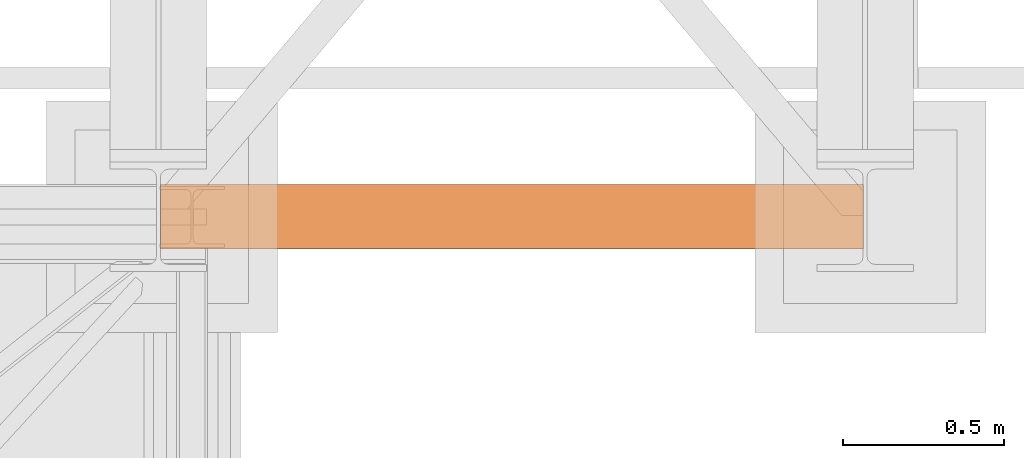
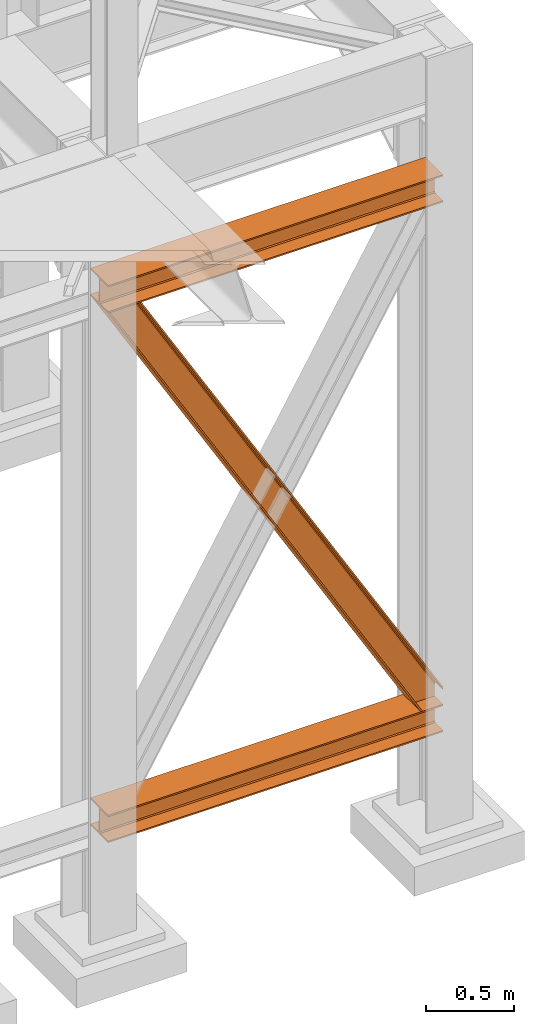
# One storey, part 80 of 208: 3 proxies.
"""IFC2X3 building model written with IfcOpenShell, lengths in millimetres."""

import ifcopenshell
import ifcopenshell.guid

model = None  # the IFC model being written
_history = None  # IfcOwnerHistory: only IFC2X3 demands one
_inside = {}  # id of a spatial element -> (the spatial element, [elements in it])
_under = {}  # id of a project, library or spatial element -> (it, [spatial elements below it])
_declared = {}  # id of a project -> (the project, [libraries it declares])
_typed = {}  # id of a type object -> (the type object, [elements of that type])
_made_of = {}  # id of a material, layer set ... -> (it, [elements and type objects made of it])


def new_model(schema):
    """Start an empty IFC model of exactly this schema.

    Asked for "IFC4X3", IfcOpenShell would pick the latest addendum, in which some entities
    have other attributes; the version numbers below select the first issue.
    IFC2X3 requires an IfcOwnerHistory on every rooted entity: one is made here for all.
    """
    global model, _history
    if schema == "IFC4X3":
        model = ifcopenshell.file(schema_version=(4, 3, 0, 0))
    else:
        model = ifcopenshell.file(schema=schema)
    _inside.clear()
    _under.clear()
    _declared.clear()
    _typed.clear()
    _made_of.clear()
    _history = None
    if model.schema == "IFC2X3":
        org = make("IfcOrganization", Name="unknown")
        user = make(
            "IfcPersonAndOrganization",
            ThePerson=make("IfcPerson", FamilyName="unknown"),
            TheOrganization=org,
        )
        app = make(
            "IfcApplication",
            ApplicationDeveloper=org,
            Version="unknown",
            ApplicationFullName="unknown",
            ApplicationIdentifier="unknown",
        )
        _history = make(
            "IfcOwnerHistory",
            OwningUser=user,
            OwningApplication=app,
            ChangeAction="ADDED",
            CreationDate=0,
        )
    return model


def make(cls, **values):
    """One entity of the class cls with the attributes given. An attribute that is None is left unset."""
    return model.create_entity(
        cls, **{name: value for name, value in values.items() if value is not None}
    )


def entity(cls, *values):
    """Any entity or typed value of the class cls, its attributes in the order of the schema. None: left unset."""
    e = model.create_entity(cls)
    for i, value in enumerate(values):
        if value is not None:
            e[i] = value
    return e


def rooted(cls, **values):
    """An entity with a GlobalId (a new one), such as an element, a storey or a relation."""
    return make(cls, GlobalId=ifcopenshell.guid.new(), OwnerHistory=_history, **values)


def si_unit(unit_type, name, prefix=None):
    """IfcSIUnit, for example si_unit("LENGTHUNIT", "METRE", prefix="MILLI")."""
    return make("IfcSIUnit", UnitType=unit_type, Prefix=prefix, Name=name)


def converted_unit(unit_type, name, factor, base, dimensions=None, offset=None):
    """IfcConversionBasedUnit, such as the inch: factor (a typed value) times the base unit."""
    return make(
        "IfcConversionBasedUnit"
        if offset is None
        else "IfcConversionBasedUnitWithOffset",
        ConversionOffset=offset,
        Dimensions=None
        if dimensions is None
        else entity("IfcDimensionalExponents", *dimensions),
        UnitType=unit_type,
        Name=name,
        ConversionFactor=make(
            "IfcMeasureWithUnit", ValueComponent=factor, UnitComponent=base
        ),
    )


def assignment(units):
    """IfcUnitAssignment: the units of a project."""
    return None if units is None else make("IfcUnitAssignment", Units=units)


def point(xyz):
    """IfcCartesianPoint."""
    return None if xyz is None else make("IfcCartesianPoint", Coordinates=xyz)


def direction(xyz):
    """IfcDirection."""
    return None if xyz is None else make("IfcDirection", DirectionRatios=xyz)


def frame(location, z_axis=None, x_axis=None):
    """IfcAxis2Placement3D, a coordinate frame: its origin and axes. An axis left out is left unset."""
    return make(
        "IfcAxis2Placement3D",
        Location=point(location),
        Axis=direction(z_axis),
        RefDirection=direction(x_axis),
    )


def origin():
    """The frame at (0, 0, 0) with its axes left unset."""
    return frame((0.0, 0.0, 0.0))


def origin_with_axes():
    """The frame at (0, 0, 0) with the z axis (0, 0, 1) and the x axis (1, 0, 0) written out."""
    return frame((0.0, 0.0, 0.0), z_axis=(0.0, 0.0, 1.0), x_axis=(1.0, 0.0, 0.0))


def place(relative_to, where):
    """IfcLocalPlacement: puts the frame where relative to a parent placement (None: the world)."""
    return make(
        "IfcLocalPlacement", PlacementRelTo=relative_to, RelativePlacement=where
    )


def context(
    kind, dimensions, precision=None, world=None, true_north=None, identifier=None
):
    """IfcGeometricRepresentationContext, for example the 3D "Model" context."""
    return make(
        "IfcGeometricRepresentationContext",
        ContextIdentifier=identifier,
        ContextType=kind,
        CoordinateSpaceDimension=dimensions,
        Precision=precision,
        WorldCoordinateSystem=world,
        TrueNorth=true_north,
    )


def subcontext(parent, identifier, kind, view, scale=None):
    """IfcGeometricRepresentationSubContext, for example "Body" below "Model"."""
    return make(
        "IfcGeometricRepresentationSubContext",
        ContextIdentifier=identifier,
        ContextType=kind,
        ParentContext=parent,
        TargetScale=scale,
        TargetView=view,
    )


def project(units=None, contexts=None):
    """IfcProject with its units and contexts."""
    return rooted(
        "IfcProject",
        Name="project",
        RepresentationContexts=contexts,
        UnitsInContext=assignment(units),
    )


def spatial(cls, under=None, at=None, **own):
    """A site, building, storey or space (cls), placed at a placement, below another one or the project."""
    s = rooted(cls, ObjectPlacement=at, **own)
    if under is not None:
        _under.setdefault(under.id(), (under, []))[1].append(s)
    return s


def faces_of(points, faces, orient=None, outer=None):
    """IfcFace entities. A face is a list of loops; a loop is a list of indices into points, from 0.

    orient and outer hold one flag for each loop. By default every Orientation is true, the
    first loop of a face is its IfcFaceOuterBound and the others are IfcFaceBound.
    """
    made = []
    for i, loops in enumerate(faces):
        bounds = []
        for j, loop in enumerate(loops):
            is_outer = j == 0 if outer is None else outer[i][j]
            bounds.append(
                make(
                    "IfcFaceOuterBound" if is_outer else "IfcFaceBound",
                    Bound=make("IfcPolyLoop", Polygon=[points[k] for k in loop]),
                    Orientation=True if orient is None else orient[i][j],
                )
            )
        made.append(make("IfcFace", Bounds=bounds))
    return made


def faceted_brep(points, faces, orient=None, outer=None, voids=None):
    """IfcFacetedBrep: a solid bounded by flat faces; with voids (closed shells), ...WithVoids."""
    shared = [point(p) for p in points]
    hull = make("IfcClosedShell", CfsFaces=faces_of(shared, faces, orient, outer))
    if voids is None:
        return make("IfcFacetedBrep", Outer=hull)
    return make(
        "IfcFacetedBrepWithVoids",
        Outer=hull,
        Voids=[
            make(cls, CfsFaces=faces_of(shared, fs, o, b)) for cls, fs, o, b in voids
        ],
    )


def shape(context_of_items, identifier, shape_type, items):
    """IfcShapeRepresentation: the items that make up one representation, for example the "Body"."""
    return make(
        "IfcShapeRepresentation",
        ContextOfItems=context_of_items,
        RepresentationIdentifier=identifier,
        RepresentationType=shape_type,
        Items=items,
    )


def made_of(thing, what):
    """Note that an element or type object is made of a material, layer set ...; save() writes the relation."""
    if what is not None:
        _made_of.setdefault(what.id(), (what, []))[1].append(thing)
    return thing


def element(
    cls,
    number,
    at=None,
    inside=None,
    cuts=None,
    type_object=None,
    material=None,
    context=None,
    identifier="Body",
    shape_type=None,
    held_by="IfcProductDefinitionShape",
    body=None,
    shapes=None,
    **own,
):
    """One element of the class cls, such as IfcWall. Its Tag is "e" and its number.

    at: its placement. inside: the storey or other place that contains it. cuts: it is an
    opening in that element (IfcRelVoidsElement). A single representation is given by context,
    identifier, shape_type and body (its items); several are given by shapes. held_by: the class
    of the entity that holds the representations. save() writes the other relations.
    """
    e = rooted(cls, Tag="e%d" % number, ObjectPlacement=at, **own)
    if body is not None:
        shapes = [shape(context, identifier, shape_type, body)]
    if shapes is not None:
        e.Representation = make(held_by, Representations=shapes)
    if inside is not None:
        _inside.setdefault(inside.id(), (inside, []))[1].append(e)
    if cuts is not None:
        rooted(
            "IfcRelVoidsElement", RelatingBuildingElement=cuts, RelatedOpeningElement=e
        )
    if type_object is not None:
        _typed.setdefault(type_object.id(), (type_object, []))[1].append(e)
    return made_of(e, material)


def aggregate(whole, parts):
    """IfcRelAggregates: a whole, such as a stair, and the parts it consists of."""
    return rooted("IfcRelAggregates", RelatingObject=whole, RelatedObjects=parts)


def save(model, path):
    """Write the relations noted so far, then the file.

    IfcRelAggregates (storeys below a building ...), IfcRelContainedInSpatialStructure (elements
    in a storey), IfcRelDefinesByType, IfcRelAssociatesMaterial and IfcRelDeclares: one each for
    every whole, place, type object, material and project.
    """
    for whole, parts in _under.values():
        aggregate(whole, parts)
    for where, things in _inside.values():
        rooted(
            "IfcRelContainedInSpatialStructure",
            RelatedElements=things,
            RelatingStructure=where,
        )
    for kind, things in _typed.values():
        rooted("IfcRelDefinesByType", RelatedObjects=things, RelatingType=kind)
    for what, things in _made_of.values():
        rooted("IfcRelAssociatesMaterial", RelatedObjects=things, RelatingMaterial=what)
    for by, libraries in _declared.values():
        rooted("IfcRelDeclares", RelatingContext=by, RelatedDefinitions=libraries)
    model.write(path)


model = new_model("IFC2X3")

# Units and contexts
model_context = context("Model", 3, precision=1e-05, world=origin())
plan_context = context("Plan", 3, precision=1e-05, world=origin())
body_context = subcontext(model_context, "Body", "Model", "MODEL_VIEW")
ifc_project = project(units=[si_unit("LENGTHUNIT", "METRE", prefix="MILLI"), converted_unit("PLANEANGLEUNIT", "DEGREE", entity("IfcPlaneAngleMeasure", 0.0174532925199433), si_unit("PLANEANGLEUNIT", "RADIAN"), dimensions=[0, 0, 0, 0, 0, 0, 0]), si_unit("AREAUNIT", "SQUARE_METRE"), si_unit("VOLUMEUNIT", "CUBIC_METRE")], contexts=[model_context, plan_context])

# Building, storey
building_placement = place(None, origin())
building = spatial("IfcBuilding", under=ifc_project, at=building_placement, CompositionType="COMPLEX")
storey_placement = place(building_placement, origin_with_axes())
storey = spatial("IfcBuildingStorey", under=building, at=storey_placement, Name="Geschoss", CompositionType="ELEMENT")

# Proxies
proxy_1_placement = place(storey_placement, frame((6600.004974593441, -17362.5323246858, 544.9900024165573), z_axis=(0.0, 0.0, 1.0), x_axis=(1.0, 0.0, 0.0)))
element("IfcBuildingElementProxy", 1, at=proxy_1_placement, inside=storey, context=body_context, shape_type="Brep", body=[
    faceted_brep([(2188.00999989569, 0.00999999999839929, 190.0100125169756), (2188.00999989569, 200.0100029802306, 190.0100125169756), (2188.00999989569, 200.0100029802306, 180.0100146031382), (2188.00999989569, 121.2600035762771, 180.0100071525576), (2188.00999989569, 111.9441915473326, 178.1454621052744), (2188.00999989569, 105.1245498640819, 171.3258190250399), (2188.00999989569, 103.2600015571697, 162.010007927418), (2188.00999989569, 103.2600015571697, 28.00999713897727), (2188.00999989569, 105.1245498640819, 18.69418604135535), (2188.00999989569, 111.9441915473326, 11.87454296112082), (2188.00999989569, 121.2600035762771, 10.00999791383765), (2188.00999989569, 200.0100029802306, 10.00999791383765), (2188.00999989569, 200.0100029802306, 0.01000000000021828), (2188.00999989569, 0.00999999999839929, 0.01000000000021828), (2188.00999989569, 0.00999999999839929, 10.00999791383765), (2188.00999989569, 78.75999940395195, 10.00999791383765), (2188.00999989569, 88.07581143289644, 11.87454296112082), (2188.00999989569, 94.89545311614711, 18.69418604135535), (2188.00999989569, 96.7600014230593, 28.00999713897727), (2188.00999989569, 96.7600014230593, 162.010007927418), (2188.00999989569, 94.89545311614711, 171.3258190250399), (2188.00999989569, 88.07581143289644, 178.1454621052744), (2188.00999989569, 78.75999940395195, 180.0100071525576), (2188.00999989569, 0.00999999999839929, 180.0100146031382), (2188.00999989569, 200.0100029802306, 190.0100125169756), (2188.00999989569, 0.00999999999839929, 190.0100125169756), (0.01000000000021828, 0.00999999999839929, 190.0100125169755), (0.01000000000021828, 200.0100029802306, 190.0100125169755), (2188.00999989569, 200.0100029802306, 180.0100146031382), (2188.00999989569, 200.0100029802306, 190.0100125169756), (0.01000000000021828, 200.0100029802306, 190.0100125169755), (0.01000000000021828, 200.0100029802306, 180.0100146031381), (2188.00999989569, 121.2600035762771, 180.0100071525576), (2188.00999989569, 200.0100029802306, 180.0100146031382), (0.01000000000021828, 200.0100029802306, 180.0100146031381), (0.01000000000021828, 121.2600035762771, 180.0100071525575), (2188.00999989569, 111.9441915473326, 178.1454621052744), (2188.00999989569, 121.2600035762771, 180.0100071525576), (0.01000000000021828, 121.2600035762771, 180.0100071525575), (0.01000000000021828, 111.9441915473326, 178.1454621052743), (2188.00999989569, 105.1245498640819, 171.3258190250399), (2188.00999989569, 111.9441915473326, 178.1454621052744), (0.01000000000021828, 111.9441915473326, 178.1454621052743), (0.01000000000021828, 105.1245498640819, 171.3258190250398), (2188.00999989569, 103.2600015571697, 162.010007927418), (2188.00999989569, 105.1245498640819, 171.3258190250399), (0.01000000000021828, 105.1245498640819, 171.3258190250398), (0.01000000000021828, 103.2600015571697, 162.0100079274179), (2188.00999989569, 103.2600015571697, 28.00999713897727), (2188.00999989569, 103.2600015571697, 162.010007927418), (0.01000000000021828, 103.2600015571697, 162.0100079274179), (0.01000000000021828, 103.2600015571697, 28.00999713897716), (2188.00999989569, 105.1245498640819, 18.69418604135535), (2188.00999989569, 103.2600015571697, 28.00999713897727), (0.01000000000021828, 103.2600015571697, 28.00999713897716), (0.01000000000021828, 105.1245498640819, 18.69418604135524), (2188.00999989569, 111.9441915473326, 11.87454296112082), (2188.00999989569, 105.1245498640819, 18.69418604135535), (0.01000000000021828, 105.1245498640819, 18.69418604135524), (0.01000000000021828, 111.9441915473326, 11.87454296112071), (2188.00999989569, 121.2600035762771, 10.00999791383765), (2188.00999989569, 111.9441915473326, 11.87454296112082), (0.01000000000021828, 111.9441915473326, 11.87454296112071), (0.01000000000021828, 121.2600035762771, 10.00999791383754), (2188.00999989569, 200.0100029802306, 10.00999791383765), (2188.00999989569, 121.2600035762771, 10.00999791383765), (0.01000000000021828, 121.2600035762771, 10.00999791383754), (0.01000000000021828, 200.0100029802306, 10.00999791383754), (2188.00999989569, 200.0100029802306, 0.01000000000021828), (2188.00999989569, 200.0100029802306, 10.00999791383765), (0.01000000000021828, 200.0100029802306, 10.00999791383754), (0.01000000000021828, 200.0100029802306, 0.01000000000010459), (2188.00999989569, 0.00999999999839929, 0.01000000000021828), (2188.00999989569, 200.0100029802306, 0.01000000000021828), (0.01000000000021828, 200.0100029802306, 0.01000000000010459), (0.01000000000021828, 0.00999999999839929, 0.01000000000010459), (2188.00999989569, 0.00999999999839929, 10.00999791383765), (2188.00999989569, 0.00999999999839929, 0.01000000000021828), (0.01000000000021828, 0.00999999999839929, 0.01000000000010459), (0.01000000000021828, 0.00999999999839929, 10.00999791383754), (2188.00999989569, 78.75999940395195, 10.00999791383765), (2188.00999989569, 0.00999999999839929, 10.00999791383765), (0.01000000000021828, 0.00999999999839929, 10.00999791383754), (0.01000000000021828, 78.75999940395195, 10.00999791383754), (2188.00999989569, 88.07581143289644, 11.87454296112082), (2188.00999989569, 78.75999940395195, 10.00999791383765), (0.01000000000021828, 78.75999940395195, 10.00999791383754), (0.01000000000021828, 88.07581143289644, 11.87454296112071), (2188.00999989569, 94.89545311614711, 18.69418604135535), (2188.00999989569, 88.07581143289644, 11.87454296112082), (0.01000000000021828, 88.07581143289644, 11.87454296112071), (0.01000000000021828, 94.89545311614711, 18.69418604135524), (2188.00999989569, 96.7600014230593, 28.00999713897727), (2188.00999989569, 94.89545311614711, 18.69418604135535), (0.01000000000021828, 94.89545311614711, 18.69418604135524), (0.01000000000021828, 96.7600014230593, 28.00999713897716), (2188.00999989569, 96.7600014230593, 162.010007927418), (2188.00999989569, 96.7600014230593, 28.00999713897727), (0.01000000000021828, 96.7600014230593, 28.00999713897716), (0.01000000000021828, 96.7600014230593, 162.0100079274179), (2188.00999989569, 94.89545311614711, 171.3258190250399), (2188.00999989569, 96.7600014230593, 162.010007927418), (0.01000000000021828, 96.7600014230593, 162.0100079274179), (0.01000000000021828, 94.89545311614711, 171.3258190250398), (2188.00999989569, 88.07581143289644, 178.1454621052744), (2188.00999989569, 94.89545311614711, 171.3258190250399), (0.01000000000021828, 94.89545311614711, 171.3258190250398), (0.01000000000021828, 88.07581143289644, 178.1454621052743), (2188.00999989569, 78.75999940395195, 180.0100071525576), (2188.00999989569, 88.07581143289644, 178.1454621052744), (0.01000000000021828, 88.07581143289644, 178.1454621052743), (0.01000000000021828, 78.75999940395195, 180.0100071525575), (2188.00999989569, 0.00999999999839929, 180.0100146031382), (2188.00999989569, 78.75999940395195, 180.0100071525576), (0.01000000000021828, 78.75999940395195, 180.0100071525575), (0.01000000000021828, 0.00999999999839929, 180.0100146031381), (2188.00999989569, 0.00999999999839929, 190.0100125169756), (2188.00999989569, 0.00999999999839929, 180.0100146031382), (0.01000000000021828, 0.00999999999839929, 180.0100146031381), (0.01000000000021828, 0.00999999999839929, 190.0100125169755), (0.01000000000021828, 0.00999999999839929, 190.0100125169755), (0.01000000000021828, 0.00999999999839929, 180.0100146031381), (0.01000000000021828, 78.75999940395195, 180.0100071525575), (0.01000000000021828, 88.07581143289644, 178.1454621052743), (0.01000000000021828, 94.89545311614711, 171.3258190250398), (0.01000000000021828, 96.7600014230593, 162.0100079274179), (0.01000000000021828, 96.7600014230593, 28.00999713897716), (0.01000000000021828, 94.89545311614711, 18.69418604135524), (0.01000000000021828, 88.07581143289644, 11.87454296112071), (0.01000000000021828, 78.75999940395195, 10.00999791383754), (0.01000000000021828, 0.00999999999839929, 10.00999791383754), (0.01000000000021828, 0.00999999999839929, 0.01000000000010459), (0.01000000000021828, 200.0100029802306, 0.01000000000010459), (0.01000000000021828, 200.0100029802306, 10.00999791383754), (0.01000000000021828, 121.2600035762771, 10.00999791383754), (0.01000000000021828, 111.9441915473326, 11.87454296112071), (0.01000000000021828, 105.1245498640819, 18.69418604135524), (0.01000000000021828, 103.2600015571697, 28.00999713897716), (0.01000000000021828, 103.2600015571697, 162.0100079274179), (0.01000000000021828, 105.1245498640819, 171.3258190250398), (0.01000000000021828, 111.9441915473326, 178.1454621052743), (0.01000000000021828, 121.2600035762771, 180.0100071525575), (0.01000000000021828, 200.0100029802306, 180.0100146031381), (0.01000000000021828, 200.0100029802306, 190.0100125169755)], [[[0, 1, 2, 3, 4, 5, 6, 7, 8, 9, 10, 11, 12, 13, 14, 15, 16, 17, 18, 19, 20, 21, 22, 23]], [[24, 25, 26, 27]], [[28, 29, 30, 31]], [[32, 33, 34, 35]], [[36, 37, 38, 39]], [[40, 41, 42, 43]], [[44, 45, 46, 47]], [[48, 49, 50, 51]], [[52, 53, 54, 55]], [[56, 57, 58, 59]], [[60, 61, 62, 63]], [[64, 65, 66, 67]], [[68, 69, 70, 71]], [[72, 73, 74, 75]], [[76, 77, 78, 79]], [[80, 81, 82, 83]], [[84, 85, 86, 87]], [[88, 89, 90, 91]], [[92, 93, 94, 95]], [[96, 97, 98, 99]], [[100, 101, 102, 103]], [[104, 105, 106, 107]], [[108, 109, 110, 111]], [[112, 113, 114, 115]], [[116, 117, 118, 119]], [[120, 121, 122, 123, 124, 125, 126, 127, 128, 129, 130, 131, 132, 133, 134, 135, 136, 137, 138, 139, 140, 141, 142, 143]]], orient=[[False], [False], [False], [False], [False], [False], [False], [False], [False], [False], [False], [False], [False], [False], [False], [False], [False], [False], [False], [False], [False], [False], [False], [False], [False], [False]]),
])
proxy_2_placement = place(storey_placement, frame((6600.004974593441, -17362.5323246858, 4202.989992847441), z_axis=(0.0, 0.0, 1.0), x_axis=(1.0, 0.0, 0.0)))
element("IfcBuildingElementProxy", 2, at=proxy_2_placement, inside=storey, context=body_context, shape_type="Brep", body=[
    faceted_brep([(2188.00999989569, 0.00999999999839929, 190.0100125169756), (2188.00999989569, 200.0100029802306, 190.0100125169756), (2188.00999989569, 200.0100029802306, 180.0100146031382), (2188.00999989569, 121.2600035762771, 180.0100071525576), (2188.00999989569, 111.9441915473326, 178.1454621052744), (2188.00999989569, 105.1245498640819, 171.3258190250399), (2188.00999989569, 103.2600015571697, 162.010007927418), (2188.00999989569, 103.2600015571697, 28.00999713897727), (2188.00999989569, 105.1245498640819, 18.69418604135535), (2188.00999989569, 111.9441915473326, 11.87454296112082), (2188.00999989569, 121.2600035762771, 10.00999791383765), (2188.00999989569, 200.0100029802306, 10.00999791383765), (2188.00999989569, 200.0100029802306, 0.01000000000021828), (2188.00999989569, 0.00999999999839929, 0.01000000000021828), (2188.00999989569, 0.00999999999839929, 10.00999791383765), (2188.00999989569, 78.75999940395195, 10.00999791383765), (2188.00999989569, 88.07581143289644, 11.87454296112082), (2188.00999989569, 94.89545311614711, 18.69418604135535), (2188.00999989569, 96.7600014230593, 28.00999713897727), (2188.00999989569, 96.7600014230593, 162.010007927418), (2188.00999989569, 94.89545311614711, 171.3258190250399), (2188.00999989569, 88.07581143289644, 178.1454621052744), (2188.00999989569, 78.75999940395195, 180.0100071525576), (2188.00999989569, 0.00999999999839929, 180.0100146031382), (2188.00999989569, 200.0100029802306, 190.0100125169756), (2188.00999989569, 0.00999999999839929, 190.0100125169756), (0.01000000000021828, 0.00999999999839929, 190.0100125169756), (0.01000000000021828, 200.0100029802306, 190.0100125169756), (2188.00999989569, 200.0100029802306, 180.0100146031382), (2188.00999989569, 200.0100029802306, 190.0100125169756), (0.01000000000021828, 200.0100029802306, 190.0100125169756), (0.01000000000021828, 200.0100029802306, 180.0100146031382), (2188.00999989569, 121.2600035762771, 180.0100071525576), (2188.00999989569, 200.0100029802306, 180.0100146031382), (0.01000000000021828, 200.0100029802306, 180.0100146031382), (0.01000000000021828, 121.2600035762771, 180.0100071525576), (2188.00999989569, 111.9441915473326, 178.1454621052744), (2188.00999989569, 121.2600035762771, 180.0100071525576), (0.01000000000021828, 121.2600035762771, 180.0100071525576), (0.01000000000021828, 111.9441915473326, 178.1454621052744), (2188.00999989569, 105.1245498640819, 171.3258190250399), (2188.00999989569, 111.9441915473326, 178.1454621052744), (0.01000000000021828, 111.9441915473326, 178.1454621052744), (0.01000000000021828, 105.1245498640819, 171.3258190250399), (2188.00999989569, 103.2600015571697, 162.010007927418), (2188.00999989569, 105.1245498640819, 171.3258190250399), (0.01000000000021828, 105.1245498640819, 171.3258190250399), (0.01000000000021828, 103.2600015571697, 162.010007927418), (2188.00999989569, 103.2600015571697, 28.00999713897727), (2188.00999989569, 103.2600015571697, 162.010007927418), (0.01000000000021828, 103.2600015571697, 162.010007927418), (0.01000000000021828, 103.2600015571697, 28.00999713897727), (2188.00999989569, 105.1245498640819, 18.69418604135535), (2188.00999989569, 103.2600015571697, 28.00999713897727), (0.01000000000021828, 103.2600015571697, 28.00999713897727), (0.01000000000021828, 105.1245498640819, 18.69418604135535), (2188.00999989569, 111.9441915473326, 11.87454296112082), (2188.00999989569, 105.1245498640819, 18.69418604135535), (0.01000000000021828, 105.1245498640819, 18.69418604135535), (0.01000000000021828, 111.9441915473326, 11.87454296112082), (2188.00999989569, 121.2600035762771, 10.00999791383765), (2188.00999989569, 111.9441915473326, 11.87454296112082), (0.01000000000021828, 111.9441915473326, 11.87454296112082), (0.01000000000021828, 121.2600035762771, 10.00999791383765), (2188.00999989569, 200.0100029802306, 10.00999791383765), (2188.00999989569, 121.2600035762771, 10.00999791383765), (0.01000000000021828, 121.2600035762771, 10.00999791383765), (0.01000000000021828, 200.0100029802306, 10.00999791383765), (2188.00999989569, 200.0100029802306, 0.01000000000021828), (2188.00999989569, 200.0100029802306, 10.00999791383765), (0.01000000000021828, 200.0100029802306, 10.00999791383765), (0.01000000000021828, 200.0100029802306, 0.01000000000021828), (2188.00999989569, 0.00999999999839929, 0.01000000000021828), (2188.00999989569, 200.0100029802306, 0.01000000000021828), (0.01000000000021828, 200.0100029802306, 0.01000000000021828), (0.01000000000021828, 0.00999999999839929, 0.01000000000021828), (2188.00999989569, 0.00999999999839929, 10.00999791383765), (2188.00999989569, 0.00999999999839929, 0.01000000000021828), (0.01000000000021828, 0.00999999999839929, 0.01000000000021828), (0.01000000000021828, 0.00999999999839929, 10.00999791383765), (2188.00999989569, 78.75999940395195, 10.00999791383765), (2188.00999989569, 0.00999999999839929, 10.00999791383765), (0.01000000000021828, 0.00999999999839929, 10.00999791383765), (0.01000000000021828, 78.75999940395195, 10.00999791383765), (2188.00999989569, 88.07581143289644, 11.87454296112082), (2188.00999989569, 78.75999940395195, 10.00999791383765), (0.01000000000021828, 78.75999940395195, 10.00999791383765), (0.01000000000021828, 88.07581143289644, 11.87454296112082), (2188.00999989569, 94.89545311614711, 18.69418604135535), (2188.00999989569, 88.07581143289644, 11.87454296112082), (0.01000000000021828, 88.07581143289644, 11.87454296112082), (0.01000000000021828, 94.89545311614711, 18.69418604135535), (2188.00999989569, 96.7600014230593, 28.00999713897727), (2188.00999989569, 94.89545311614711, 18.69418604135535), (0.01000000000021828, 94.89545311614711, 18.69418604135535), (0.01000000000021828, 96.7600014230593, 28.00999713897727), (2188.00999989569, 96.7600014230593, 162.010007927418), (2188.00999989569, 96.7600014230593, 28.00999713897727), (0.01000000000021828, 96.7600014230593, 28.00999713897727), (0.01000000000021828, 96.7600014230593, 162.010007927418), (2188.00999989569, 94.89545311614711, 171.3258190250399), (2188.00999989569, 96.7600014230593, 162.010007927418), (0.01000000000021828, 96.7600014230593, 162.010007927418), (0.01000000000021828, 94.89545311614711, 171.3258190250399), (2188.00999989569, 88.07581143289644, 178.1454621052744), (2188.00999989569, 94.89545311614711, 171.3258190250399), (0.01000000000021828, 94.89545311614711, 171.3258190250399), (0.01000000000021828, 88.07581143289644, 178.1454621052744), (2188.00999989569, 78.75999940395195, 180.0100071525576), (2188.00999989569, 88.07581143289644, 178.1454621052744), (0.01000000000021828, 88.07581143289644, 178.1454621052744), (0.01000000000021828, 78.75999940395195, 180.0100071525576), (2188.00999989569, 0.00999999999839929, 180.0100146031382), (2188.00999989569, 78.75999940395195, 180.0100071525576), (0.01000000000021828, 78.75999940395195, 180.0100071525576), (0.01000000000021828, 0.00999999999839929, 180.0100146031382), (2188.00999989569, 0.00999999999839929, 190.0100125169756), (2188.00999989569, 0.00999999999839929, 180.0100146031382), (0.01000000000021828, 0.00999999999839929, 180.0100146031382), (0.01000000000021828, 0.00999999999839929, 190.0100125169756), (0.01000000000021828, 0.00999999999839929, 190.0100125169756), (0.01000000000021828, 0.00999999999839929, 180.0100146031382), (0.01000000000021828, 78.75999940395195, 180.0100071525576), (0.01000000000021828, 88.07581143289644, 178.1454621052744), (0.01000000000021828, 94.89545311614711, 171.3258190250399), (0.01000000000021828, 96.7600014230593, 162.010007927418), (0.01000000000021828, 96.7600014230593, 28.00999713897727), (0.01000000000021828, 94.89545311614711, 18.69418604135535), (0.01000000000021828, 88.07581143289644, 11.87454296112082), (0.01000000000021828, 78.75999940395195, 10.00999791383765), (0.01000000000021828, 0.00999999999839929, 10.00999791383765), (0.01000000000021828, 0.00999999999839929, 0.01000000000021828), (0.01000000000021828, 200.0100029802306, 0.01000000000021828), (0.01000000000021828, 200.0100029802306, 10.00999791383765), (0.01000000000021828, 121.2600035762771, 10.00999791383765), (0.01000000000021828, 111.9441915473326, 11.87454296112082), (0.01000000000021828, 105.1245498640819, 18.69418604135535), (0.01000000000021828, 103.2600015571697, 28.00999713897727), (0.01000000000021828, 103.2600015571697, 162.010007927418), (0.01000000000021828, 105.1245498640819, 171.3258190250399), (0.01000000000021828, 111.9441915473326, 178.1454621052744), (0.01000000000021828, 121.2600035762771, 180.0100071525576), (0.01000000000021828, 200.0100029802306, 180.0100146031382), (0.01000000000021828, 200.0100029802306, 190.0100125169756)], [[[0, 1, 2, 3, 4, 5, 6, 7, 8, 9, 10, 11, 12, 13, 14, 15, 16, 17, 18, 19, 20, 21, 22, 23]], [[24, 25, 26, 27]], [[28, 29, 30, 31]], [[32, 33, 34, 35]], [[36, 37, 38, 39]], [[40, 41, 42, 43]], [[44, 45, 46, 47]], [[48, 49, 50, 51]], [[52, 53, 54, 55]], [[56, 57, 58, 59]], [[60, 61, 62, 63]], [[64, 65, 66, 67]], [[68, 69, 70, 71]], [[72, 73, 74, 75]], [[76, 77, 78, 79]], [[80, 81, 82, 83]], [[84, 85, 86, 87]], [[88, 89, 90, 91]], [[92, 93, 94, 95]], [[96, 97, 98, 99]], [[100, 101, 102, 103]], [[104, 105, 106, 107]], [[108, 109, 110, 111]], [[112, 113, 114, 115]], [[116, 117, 118, 119]], [[120, 121, 122, 123, 124, 125, 126, 127, 128, 129, 130, 131, 132, 133, 134, 135, 136, 137, 138, 139, 140, 141, 142, 143]]], orient=[[False], [False], [False], [False], [False], [False], [False], [False], [False], [False], [False], [False], [False], [False], [False], [False], [False], [False], [False], [False], [False], [False], [False], [False], [False], [False]]),
])
proxy_3_placement = place(storey_placement, frame((6600.58245655252, -17362.5323246858, 734.9900149335328), z_axis=(0.0, 0.0, 1.0), x_axis=(1.0, 0.0, 0.0)))
element("IfcBuildingElementProxy", 3, at=proxy_3_placement, inside=storey, context=body_context, shape_type="Brep", body=[
    faceted_brep([(2187.432517936612, 0.00999999999839929, 120.8497915510925), (216.8471928951321, 0.00999999999839929, 3468.009977913908), (216.8471928951321, 200.0100029802306, 3468.009977913908), (2187.432517936612, 200.0100029802306, 120.8497915510925), (2187.432517936612, 200.0100029802306, 120.8497915510925), (216.8471928951321, 200.0100029802306, 3468.009977913908), (205.4347121912169, 200.0100029802306, 3468.009977913908), (2187.432517936612, 200.0100029802306, 101.4682129393399), (2187.432517936612, 200.0100029802306, 101.4682129393399), (205.4347121912169, 200.0100029802306, 3468.009977913908), (205.4347036882537, 121.2600035762771, 3468.009977913908), (2187.432517936952, 121.2600035762771, 101.4681984983712), (2187.432517936952, 121.2600035762771, 101.4681984983712), (205.4347036882537, 121.2600035762771, 3468.009977913908), (203.3067948069675, 111.9441915473326, 3468.009977913909), (2187.432602958226, 111.9441915473326, 97.8542740943027), (2187.432602958226, 111.9441915473326, 97.8542740943027), (203.3067948069675, 111.9441915473326, 3468.009977913909), (195.5238886772495, 105.1245498640819, 3468.009977913908), (2187.432517936612, 105.1245498640819, 84.63689245399053), (2187.432517936612, 105.1245498640819, 84.63689245399053), (195.5238886772495, 105.1245498640819, 3468.009977913908), (184.892235020021, 103.2600015571697, 3468.009977913908), (2187.432517936612, 103.2600015571697, 66.58142866151934), (2187.432517936612, 103.2600015571697, 0.01000000000010459), (2187.432517936612, 103.2600015571697, 66.58142866151934), (184.892235020021, 103.2600015571697, 3468.009977913908), (31.96494937214811, 103.2600015571697, 3468.009977913908), (2073.723887154785, 103.2600015571697, 0.01000000000033197), (2073.723887154785, 103.2600015571697, 0.01000000000033197), (31.96494937214811, 103.2600015571697, 3468.009977913908), (21.33329571491959, 105.1245498640819, 3468.009977913908), (2063.093996904379, 105.1245498640819, 0.01000000000021828), (2063.093996904379, 105.1245498640819, 0.01000000000021828), (21.33329571491959, 105.1245498640819, 3468.009977913908), (13.55038958520254, 111.9441915473326, 3468.009977913908), (2055.312379673187, 111.9441915473326, 0.009999999999877218), (2055.312379673187, 111.9441915473326, 0.009999999999877218), (13.55038958520254, 111.9441915473326, 3468.009977913908), (11.42248070391543, 121.2600035762771, 3468.009977913907), (2053.184822892688, 121.2600035762771, 0.009999999999877218), (2053.184822892688, 121.2600035762771, 0.009999999999877218), (11.42248070391543, 121.2600035762771, 3468.009977913907), (11.42248070391634, 200.0100029802306, 3468.009977913907), (2053.184822892688, 200.0100029802306, 0.009999999999877218), (2053.184822892688, 200.0100029802306, 0.009999999999877218), (11.42248070391634, 200.0100029802306, 3468.009977913907), (0.01000000000021828, 200.0100029802306, 3468.009977913908), (2041.774228435659, 200.0100029802306, 0.01000000000010459), (2041.774228435659, 200.0100029802306, 0.01000000000010459), (0.01000000000021828, 200.0100029802306, 3468.009977913908), (0.01000000000021828, 0.00999999999839929, 3468.009977913908), (2041.774228435659, 0.00999999999839929, 0.01000000000010459), (2041.774228435659, 0.00999999999839929, 0.01000000000010459), (0.01000000000021828, 0.00999999999839929, 3468.009977913908), (11.42248070391725, 0.00999999999839929, 3468.009977913908), (2053.184822892688, 0.00999999999839929, 0.009999999999990905), (2053.184822892688, 0.00999999999839929, 0.009999999999990905), (11.42248070391725, 0.00999999999839929, 3468.009977913908), (11.42248070391634, 78.75999940395195, 3468.009977913907), (2053.184822892688, 78.75999940395195, 0.009999999999877218), (2053.184822892688, 78.75999940395195, 0.009999999999877218), (11.42248070391634, 78.75999940395195, 3468.009977913907), (13.55038958520254, 88.07581143290008, 3468.009977913908), (2055.312379673187, 88.07581143289644, 0.009999999999877218), (2055.312379673187, 88.07581143289644, 0.009999999999877218), (13.55038958520254, 88.07581143290008, 3468.009977913908), (21.33329571491959, 94.89545311614711, 3468.009977913908), (2063.093996904379, 94.89545311614711, 0.009999999999877218), (2063.093996904379, 94.89545311614711, 0.009999999999877218), (21.33329571491959, 94.89545311614711, 3468.009977913908), (31.96494937214811, 96.7600014230593, 3468.009977913908), (2073.723887154785, 96.7600014230593, 0.01000000000033197), (2073.723887154785, 96.7600014230593, 0.01000000000033197), (31.96494937214811, 96.7600014230593, 3468.009977913908), (184.892235020021, 96.7600014230593, 3468.009977913908), (2187.432517936612, 96.7600014230593, 66.581428661519), (2187.432517936612, 96.7600014230593, 0.01000000000010459), (2187.432517936612, 96.7600014230593, 66.581428661519), (184.892235020021, 96.7600014230593, 3468.009977913908), (195.5238886772495, 94.89545311614711, 3468.009977913908), (2187.432517936612, 94.89545311615075, 84.63689245399053), (2187.432517936612, 94.89545311615075, 84.63689245399053), (195.5238886772495, 94.89545311614711, 3468.009977913908), (203.3067948069675, 88.07581143289644, 3468.009977913909), (2187.432517936612, 88.07581143289644, 97.85441850857103), (2187.432517936612, 88.07581143289644, 97.85441850857103), (203.3067948069675, 88.07581143289644, 3468.009977913909), (205.4347036882546, 78.75999940395195, 3468.009977913908), (2187.432433072334, 78.75999940395195, 101.4683426459952), (2187.432433072334, 78.75999940395195, 101.4683426459952), (205.4347036882546, 78.75999940395195, 3468.009977913908), (205.4347121912169, 0.00999999999839929, 3468.009977913908), (2187.432517936273, 0.00999999999839929, 101.4682129399165), (2187.432517936273, 0.00999999999839929, 101.4682129399165), (205.4347121912169, 0.00999999999839929, 3468.009977913908), (216.8471928951321, 0.00999999999839929, 3468.009977913908), (2187.432517936612, 0.00999999999839929, 120.8497915510925), (216.8471928951321, 0.00999999999839929, 3468.009977913908), (205.4347121912169, 0.00999999999839929, 3468.009977913908), (205.4347036882546, 78.75999940395195, 3468.009977913908), (203.3067948069675, 88.07581143289644, 3468.009977913909), (195.5238886772495, 94.89545311614711, 3468.009977913908), (184.892235020021, 96.7600014230593, 3468.009977913908), (31.96494937214811, 96.7600014230593, 3468.009977913908), (21.33329571491959, 94.89545311614711, 3468.009977913908), (13.55038958520254, 88.07581143290008, 3468.009977913908), (11.42248070391634, 78.75999940395195, 3468.009977913907), (11.42248070391725, 0.00999999999839929, 3468.009977913908), (0.01000000000021828, 0.00999999999839929, 3468.009977913908), (0.01000000000021828, 200.0100029802306, 3468.009977913908), (11.42248070391634, 200.0100029802306, 3468.009977913907), (11.42248070391543, 121.2600035762771, 3468.009977913907), (13.55038958520254, 111.9441915473326, 3468.009977913908), (21.33329571491959, 105.1245498640819, 3468.009977913908), (31.96494937214811, 103.2600015571697, 3468.009977913908), (184.892235020021, 103.2600015571697, 3468.009977913908), (195.5238886772495, 105.1245498640819, 3468.009977913908), (203.3067948069675, 111.9441915473326, 3468.009977913909), (205.4347036882537, 121.2600035762771, 3468.009977913908), (205.4347121912169, 200.0100029802306, 3468.009977913908), (216.8471928951321, 200.0100029802306, 3468.009977913908), (2187.432517936612, 96.7600014230593, 0.01000000000010459), (2187.432517936612, 96.7600014230593, 66.581428661519), (2187.432517936612, 94.89545311615075, 84.63689245399053), (2187.432517936612, 88.07581143289644, 97.85441850857103), (2187.432433072334, 78.75999940395195, 101.4683426459952), (2187.432517936273, 0.00999999999839929, 101.4682129399165), (2187.432517936612, 0.00999999999839929, 120.8497915510925), (2187.432517936612, 200.0100029802306, 120.8497915510925), (2187.432517936612, 200.0100029802306, 101.4682129393399), (2187.432517936952, 121.2600035762771, 101.4681984983712), (2187.432602958226, 111.9441915473326, 97.8542740943027), (2187.432517936612, 105.1245498640819, 84.63689245399053), (2187.432517936612, 103.2600015571697, 66.58142866151934), (2187.432517936612, 103.2600015571697, 0.01000000000010459), (2073.723887154785, 103.2600015571697, 0.01000000000033197), (2063.093996904379, 105.1245498640819, 0.01000000000021828), (2055.312379673187, 111.9441915473326, 0.009999999999877218), (2053.184822892688, 121.2600035762771, 0.009999999999877218), (2053.184822892688, 200.0100029802306, 0.009999999999877218), (2041.774228435659, 200.0100029802306, 0.01000000000010459), (2041.774228435659, 0.00999999999839929, 0.01000000000010459), (2053.184822892688, 0.00999999999839929, 0.009999999999990905), (2053.184822892688, 78.75999940395195, 0.009999999999877218), (2055.312379673187, 88.07581143289644, 0.009999999999877218), (2063.093996904379, 94.89545311614711, 0.009999999999877218), (2073.723887154785, 96.7600014230593, 0.01000000000033197), (2187.432517936612, 96.7600014230593, 0.01000000000010459), (2187.432517936612, 103.2600015571697, 0.01000000000010459)], [[[0, 1, 2, 3]], [[4, 5, 6, 7]], [[8, 9, 10, 11]], [[12, 13, 14, 15]], [[16, 17, 18, 19]], [[20, 21, 22, 23]], [[24, 25, 26, 27, 28]], [[29, 30, 31, 32]], [[33, 34, 35, 36]], [[37, 38, 39, 40]], [[41, 42, 43, 44]], [[45, 46, 47, 48]], [[49, 50, 51, 52]], [[53, 54, 55, 56]], [[57, 58, 59, 60]], [[61, 62, 63, 64]], [[65, 66, 67, 68]], [[69, 70, 71, 72]], [[73, 74, 75, 76, 77]], [[78, 79, 80, 81]], [[82, 83, 84, 85]], [[86, 87, 88, 89]], [[90, 91, 92, 93]], [[94, 95, 96, 97]], [[98, 99, 100, 101, 102, 103, 104, 105, 106, 107, 108, 109, 110, 111, 112, 113, 114, 115, 116, 117, 118, 119, 120, 121]], [[122, 123, 124, 125, 126, 127, 128, 129, 130, 131, 132, 133, 134, 135]], [[136, 137, 138, 139, 140, 141, 142, 143, 144, 145, 146, 147, 148, 149]]], orient=[[False], [False], [False], [False], [False], [False], [False], [False], [False], [False], [False], [False], [False], [False], [False], [False], [False], [False], [False], [False], [False], [False], [False], [False], [False], [False], [False]]),
])

save(model, "model.ifc")
